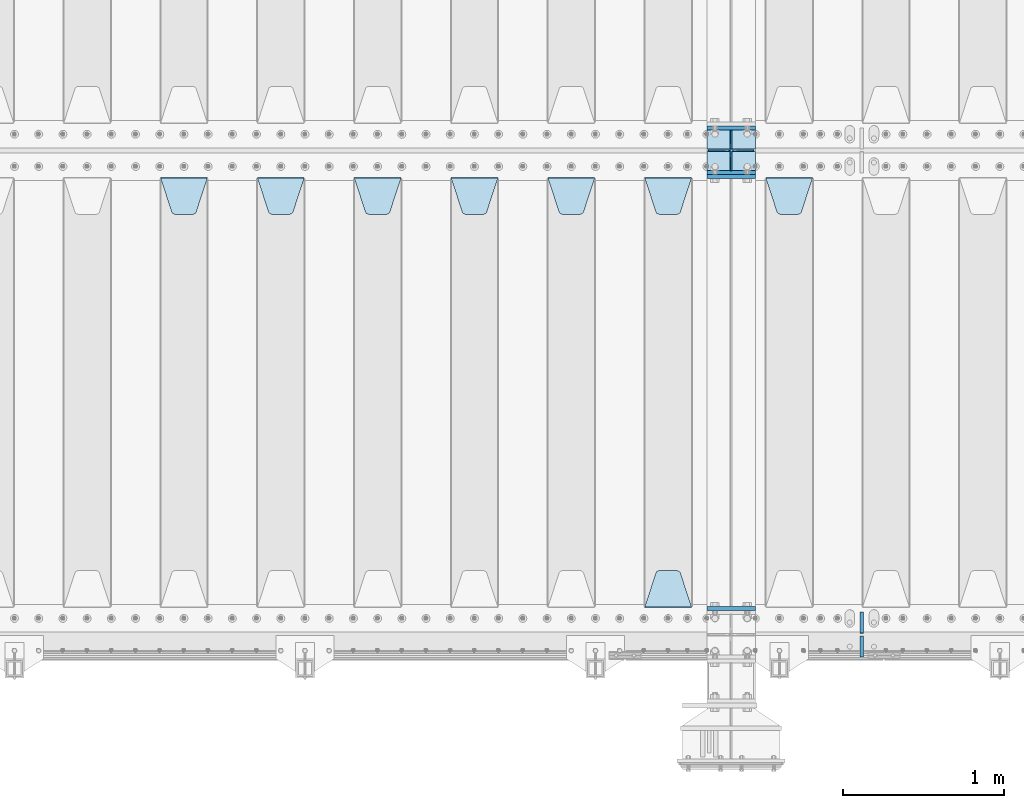
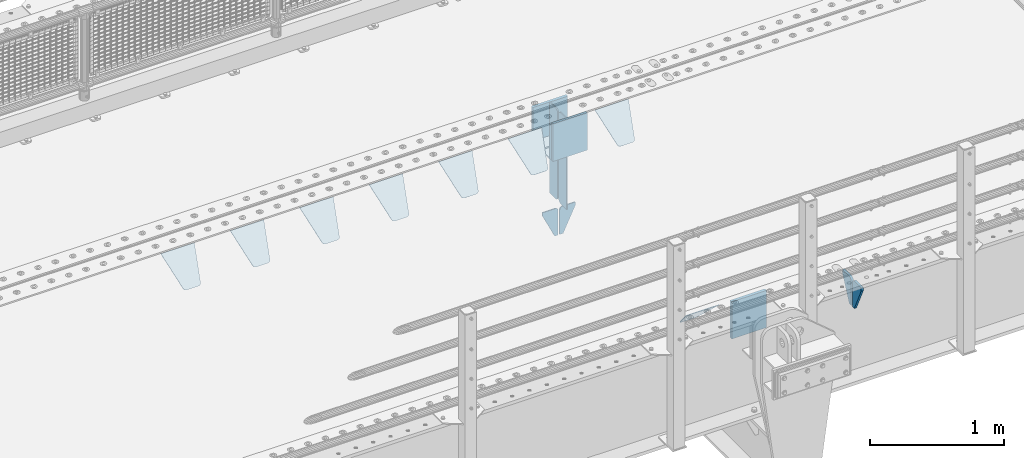
# One storey, part 167 of 193: 22 plates.
"""IFC2X3 building model written with IfcOpenShell, lengths in millimetres."""

from ifc_helpers import new_model, si_unit, frame, origin_with_axes, place, context, subcontext, project, spatial, faceted_brep, material, type_object, element, save


model = new_model("IFC2X3")

# Units and contexts
model_context = context("Model", 3, precision=1e-05, world=origin_with_axes())
body_context = subcontext(model_context, "Body", "Model", "MODEL_VIEW")
ifc_project = project(units=[si_unit("LENGTHUNIT", "METRE", prefix="MILLI"), si_unit("AREAUNIT", "SQUARE_METRE"), si_unit("VOLUMEUNIT", "CUBIC_METRE"), si_unit("MASSUNIT", "GRAM", prefix="KILO"), si_unit("TIMEUNIT", "SECOND"), si_unit("PLANEANGLEUNIT", "RADIAN"), si_unit("SOLIDANGLEUNIT", "STERADIAN"), si_unit("THERMODYNAMICTEMPERATUREUNIT", "DEGREE_CELSIUS"), si_unit("LUMINOUSINTENSITYUNIT", "LUMEN")], contexts=[model_context])

# Site, building, storey
site_placement = place(None, origin_with_axes())
site = spatial("IfcSite", under=ifc_project, at=site_placement, CompositionType="ELEMENT")
building_placement = place(site_placement, origin_with_axes())
building = spatial("IfcBuilding", under=site, at=building_placement, Name="Standard", CompositionType="ELEMENT")
storey_placement = place(building_placement, origin_with_axes())
storey = spatial("IfcBuildingStorey", under=building, at=storey_placement, Name="Undefined", CompositionType="ELEMENT", Elevation=0.0)

# Plates
ifc_material = material(Name="STEEL/S355N")
plate_type_1 = type_object("IfcPlateType", PredefinedType="NOTDEFINED")
for number, where, z_axis, x_axis in (
    (1, (-32210.0, 27137.5, -340.0), (0.0, 0.0, 1.0), (1.0, 0.0, 0.0)),
    (2, (-32210.0, 26862.5, -340.0), (0.0, 0.0, 1.0), (1.0, 0.0, 0.0)),
):
    element("IfcPlate", number, at=place(storey_placement, frame(where, z_axis=z_axis, x_axis=x_axis)), inside=storey, type_object=plate_type_1, material=ifc_material, context=body_context, shape_type="Brep", body=[
        faceted_brep([(0.0, -12.5, 0.0), (0.0, -12.5, 310.0), (0.0, 12.5, 310.0), (0.0, 12.5, 0.0), (300.0, -12.5, 310.0), (300.0, 12.5, 310.0), (300.0, -12.5, 0.0), (300.0, 12.5, 0.0)], [[[0, 1, 2, 3]], [[1, 4, 5, 2]], [[4, 6, 7, 5]], [[6, 0, 3, 7]], [[5, 7, 3, 2]], [[6, 4, 1, 0]]]),
    ])
for number, where, z_axis, x_axis in (
    (3, (-32210.0, 26837.5, -340.000000000044), (0.0, 0.0, 1.0), (1.0, 0.0, 0.0)),
    (4, (-32210.0, 24162.5, -340.000000000044), (0.0, 0.0, 1.0), (1.0, 0.0, 0.0)),
):
    element("IfcPlate", number, at=place(storey_placement, frame(where, z_axis=z_axis, x_axis=x_axis)), inside=storey, type_object=plate_type_1, material=ifc_material, context=body_context, shape_type="Brep", body=[
        faceted_brep([(0.0, -12.5, 0.0), (9.27684595808387e-10, -12.5, 340.0), (9.27684595808387e-10, 12.5, 340.0), (0.0, 12.5, 0.0), (300.0, -12.5, 340.0), (300.0, 12.5, 340.0), (300.0, -12.5, 0.0), (300.0, 12.5, 0.0)], [[[0, 1, 2, 3]], [[1, 4, 5, 2]], [[4, 6, 7, 5]], [[6, 0, 3, 7]], [[5, 7, 3, 2]], [[6, 4, 1, 0]]]),
    ])
plate_type_2 = type_object("IfcPlateType", PredefinedType="NOTDEFINED")
for number, where, z_axis, x_axis in (
    (5, (-32210.0, 26992.0, -343.0), (0.0, -1.0, 0.0), (1.0, 0.0, 0.0)),
    (6, (-32210.0, 27008.0, -343.0), (0.0, 1.0, 0.0), (1.0, 0.0, 0.0)),
):
    element("IfcPlate", number, at=place(storey_placement, frame(where, z_axis=z_axis, x_axis=x_axis)), inside=storey, type_object=plate_type_2, material=ifc_material, context=body_context, shape_type="Brep", body=[
        faceted_brep([(0.0, -7.0, 0.0), (0.0, -7.0, 117.0), (0.0, 7.0, 117.0), (0.0, 7.0, 0.0), (300.0, -7.0, 117.0), (300.0, 7.0, 117.0), (300.0, -7.0, 0.0), (300.0, 7.0, 0.0)], [[[0, 1, 2, 3]], [[1, 4, 5, 2]], [[4, 6, 7, 5]], [[6, 0, 3, 7]], [[5, 7, 3, 2]], [[6, 4, 1, 0]]]),
    ])
plate_type_3 = type_object("IfcPlateType", PredefinedType="NOTDEFINED")
for number, where, z_axis, x_axis in (
    (7, (-32060.0, 27008.0, -30.0), (0.0, 0.0, -1.0), (0.0, 1.0, 0.0)),
    (8, (-32060.0, 26992.0, -30.0), (0.0, 0.0, -1.0), (0.0, -1.0, 0.0)),
):
    element("IfcPlate", number, at=place(storey_placement, frame(where, z_axis=z_axis, x_axis=x_axis)), inside=storey, type_object=plate_type_3, material=ifc_material, context=body_context, shape_type="Brep", body=[
        faceted_brep([(0.0, -5.0, 30.0), (0.0, -5.0, 306.0), (0.0, 5.0, 306.0), (0.0, 5.0, 30.0), (117.0, -5.0, 306.0), (117.0, 5.0, 306.0), (117.0, -5.0, 0.0), (117.0, 5.0, 0.0), (30.0, -5.0, 0.0), (30.0, 5.0, 0.0), (24.7905546699913, -5.0, 0.455767409633758), (24.7905546699913, 5.0, 0.455767409633758), (19.7393957002314, -5.0, 1.80922137642275), (19.7393957002314, 5.0, 1.80922137642275), (15.0, -5.0, 4.01923788646684), (15.0, 5.0, 4.01923788646684), (10.7163717094045, -5.0, 7.01866670643066), (10.7163717094045, 5.0, 7.01866670643066), (7.01866670642994, -5.0, 10.7163717094038), (7.01866670642994, 5.0, 10.7163717094038), (4.01923788646673, -5.0, 15.0), (4.01923788646673, 5.0, 15.0), (1.80922137642119, -5.0, 19.7393957002299), (1.80922137642119, 5.0, 19.7393957002299), (0.455767409632244, -5.0, 24.7905546699921), (0.455767409632244, 5.0, 24.7905546699921)], [[[0, 1, 2, 3]], [[1, 4, 5, 2]], [[4, 6, 7, 5]], [[6, 8, 9, 7]], [[8, 10, 11, 9]], [[10, 12, 13, 11]], [[12, 14, 15, 13]], [[14, 16, 17, 15]], [[16, 18, 19, 17]], [[18, 20, 21, 19]], [[20, 22, 23, 21]], [[22, 24, 25, 23]], [[24, 0, 3, 25]], [[5, 7, 9, 11, 13, 15, 17, 19, 21, 23, 25, 3, 2]], [[24, 22, 20, 18, 16, 14, 12, 10, 8, 6, 4, 1, 0]]]),
    ])
for number, where, z_axis, x_axis in (
    (9, (-32060.0, 26992.0, -350.0), (0.0, 0.0, -1.0), (0.0, -1.0, 0.0)),
    (10, (-32060.0, 27008.0, -350.0), (0.0, 0.0, -1.0), (0.0, 1.0, 0.0)),
):
    element("IfcPlate", number, at=place(storey_placement, frame(where, z_axis=z_axis, x_axis=x_axis)), inside=storey, type_object=plate_type_3, material=ifc_material, context=body_context, shape_type="Brep", body=[
        faceted_brep([(0.0, -5.0, 0.0), (0.0, -5.0, 480.0), (0.0, 5.0, 480.0), (0.0, 5.0, 0.0), (0.455767409632244, -5.0, 485.209445330008), (0.455767409632244, 5.0, 485.209445330008), (1.80922137642119, -5.0, 490.26060429977), (1.80922137642119, 5.0, 490.26060429977), (4.01923788646673, -5.0, 495.0), (4.01923788646673, 5.0, 495.0), (7.01866670642994, -5.0, 499.283628290596), (7.01866670642994, 5.0, 499.283628290596), (10.7163717094045, -5.0, 502.981333293569), (10.7163717094045, 5.0, 502.981333293569), (15.0, -5.0, 505.980762113533), (15.0, 5.0, 505.980762113533), (19.7393957002314, -5.0, 508.190778623577), (19.7393957002314, 5.0, 508.190778623577), (24.7905546699913, -5.0, 509.544232590366), (24.7905546699913, 5.0, 509.544232590366), (30.0, -5.0, 510.0), (30.0, 5.0, 510.0), (117.0, -5.0, 510.0), (117.0, 5.0, 510.0), (117.0, -5.0, 0.0), (117.0, 5.0, 0.0)], [[[0, 1, 2, 3]], [[1, 4, 5, 2]], [[4, 6, 7, 5]], [[6, 8, 9, 7]], [[8, 10, 11, 9]], [[10, 12, 13, 11]], [[12, 14, 15, 13]], [[14, 16, 17, 15]], [[16, 18, 19, 17]], [[18, 20, 21, 19]], [[20, 22, 23, 21]], [[22, 24, 25, 23]], [[24, 0, 3, 25]], [[5, 7, 9, 11, 13, 15, 17, 19, 21, 23, 25, 3, 2]], [[24, 22, 20, 18, 16, 14, 12, 10, 8, 6, 4, 1, 0]]]),
    ])
plate_type_4 = type_object("IfcPlateType", PredefinedType="NOTDEFINED")
for number, where, z_axis, x_axis in (
    (11, (-32066.4999999343, 26999.9999999954, -915.000018206184), (0.0, 0.0, -1.0), (-1.0, 0.0, 0.0)),
    (12, (-32053.4999999343, 26999.9999999954, -915.000018206184), (0.0, 0.0, -1.0), (1.0, 0.0, 0.0)),
):
    element("IfcPlate", number, at=place(storey_placement, frame(where, z_axis=z_axis, x_axis=x_axis)), inside=storey, type_object=plate_type_4, material=ifc_material, context=body_context, shape_type="Brep", body=[
        faceted_brep([(0.0, -5.0, 27.0), (0.0, -5.0, 250.0), (0.0, 5.0, 250.0), (0.0, 5.0, 27.0), (30.0, -5.0, 250.0), (30.0, 5.0, 250.0), (135.0, -5.0, 30.0), (135.0, 5.0, 30.0), (135.0, -5.0, 0.0), (135.0, 5.0, 0.0), (27.0, -5.0, 0.0), (27.0, 5.0, 0.0), (22.3114992029914, -5.0, 0.410190668670339), (22.3114992029914, 5.0, 0.410190668670339), (17.7654561302079, -5.0, 1.62829923878041), (17.7654561302079, 5.0, 1.62829923878041), (13.5, -5.0, 3.61731409782021), (13.5, 5.0, 3.61731409782021), (9.64473453846222, -5.0, 6.31680003578765), (9.64473453846222, 5.0, 6.31680003578765), (6.31680003578731, -5.0, 9.64473453846347), (6.31680003578731, 5.0, 9.64473453846347), (3.61731409782078, -5.0, 13.5), (3.61731409782078, 5.0, 13.5), (1.62829923877871, -5.0, 17.765456130207), (1.62829923877871, 5.0, 17.765456130207), (0.410190668670111, -5.0, 22.3114992029929), (0.410190668670111, 5.0, 22.3114992029929)], [[[0, 1, 2, 3]], [[1, 4, 5, 2]], [[4, 6, 7, 5]], [[6, 8, 9, 7]], [[8, 10, 11, 9]], [[10, 12, 13, 11]], [[12, 14, 15, 13]], [[14, 16, 17, 15]], [[16, 18, 19, 17]], [[18, 20, 21, 19]], [[20, 22, 23, 21]], [[22, 24, 25, 23]], [[24, 26, 27, 25]], [[26, 0, 3, 27]], [[5, 7, 9, 11, 13, 15, 17, 19, 21, 23, 25, 27, 3, 2]], [[26, 24, 22, 20, 18, 16, 14, 12, 10, 8, 6, 4, 1, 0]]]),
    ])
plate_type_5 = type_object("IfcPlateType", PredefinedType="NOTDEFINED")
plate_1_placement = place(storey_placement, frame((-31845.0, 26831.767766956, -1.76776695296758), z_axis=(0.0, -0.707106781186547, -0.707106781186548), x_axis=(1.0, 0.0, 0.0)))
element("IfcPlate", 13, at=plate_1_placement, inside=storey, type_object=plate_type_5, material=ifc_material, context=body_context, shape_type="Brep", body=[
    faceted_brep([(0.0, -2.5, 0.0), (69.345504679477, -2.50000000000364, 300.171731424831), (69.345504679477, 2.49999999999636, 300.171731424831), (0.0, 2.5, 0.0), (70.9274061199576, -2.50000000000364, 304.897442415397), (70.9274061199576, 2.49999999999636, 304.897442415397), (73.3818627772307, -2.50000000000364, 309.234538108529), (73.3818627772307, 2.49999999999636, 309.234538108529), (76.6187032999551, -2.50000000000728, 313.023683126103), (76.6187032999551, 2.49999999999636, 313.023683126103), (80.5190132704993, -2.50000000000364, 316.125672595372), (80.5190132704993, 2.49999999999636, 316.125672595368), (84.9395038596849, -2.50000000000364, 318.426546230472), (84.9395038596849, 2.49999999999636, 318.426546230476), (89.7177759439219, -2.50000000000364, 319.841774983273), (89.7177759439219, 2.49999999999636, 319.841774983277), (94.678286292652, -2.50000000000364, 320.319366455074), (94.678286292652, 2.49999999999636, 320.319366455074), (195.321713707348, -2.50000000000364, 320.319366455074), (195.321713707348, 2.49999999999636, 320.319366455074), (200.282224056078, -2.50000000000364, 319.841774983273), (200.282224056078, 2.49999999999636, 319.841774983277), (205.060496140315, -2.50000000000364, 318.426546230472), (205.060496140315, 2.49999999999636, 318.426546230472), (209.480986729501, -2.50000000000364, 316.125672595372), (209.480986729501, 2.49999999999636, 316.125672595368), (213.381296700045, -2.50000000000728, 313.023683126103), (213.381296700045, 2.49999999999272, 313.023683126103), (216.618137222769, -2.50000000000364, 309.234538108525), (216.618137222769, 2.49999999999636, 309.234538108522), (219.072593880042, -2.50000000000364, 304.897442415397), (219.072593880042, 2.49999999999636, 304.897442415397), (220.654495320523, -2.50000000000364, 300.171731424831), (220.654495320523, 2.49999999999636, 300.171731424831), (290.0, -2.50000000000364, 0.0), (290.0, 2.49999999999636, 0.0)], [[[0, 1, 2, 3]], [[1, 4, 5, 2]], [[4, 6, 7, 5]], [[6, 8, 9, 7]], [[8, 10, 11, 9]], [[10, 12, 13, 11]], [[12, 14, 15, 13]], [[14, 16, 17, 15]], [[16, 18, 19, 17]], [[18, 20, 21, 19]], [[20, 22, 23, 21]], [[22, 24, 25, 23]], [[24, 26, 27, 25]], [[26, 28, 29, 27]], [[28, 30, 31, 29]], [[30, 32, 33, 31]], [[32, 34, 35, 33]], [[34, 0, 3, 35]], [[5, 7, 9, 11, 13, 15, 17, 19, 21, 23, 25, 27, 29, 31, 33, 35, 3, 2]], [[34, 32, 30, 28, 26, 24, 22, 20, 18, 16, 14, 12, 10, 8, 6, 4, 1, 0]]]),
])
plate_2_placement = place(storey_placement, frame((-32595.0, 26831.767766956, -1.76776695296758), z_axis=(0.0, -0.707106781186547, -0.707106781186548), x_axis=(1.0, 0.0, 0.0)))
element("IfcPlate", 14, at=plate_2_placement, inside=storey, type_object=plate_type_5, material=ifc_material, context=body_context, shape_type="Brep", body=[
    faceted_brep([(0.0, -2.5, 0.0), (69.345504679477, -2.50000000000364, 300.171731424831), (69.345504679477, 2.49999999999636, 300.171731424831), (0.0, 2.5, 0.0), (70.9274061199576, -2.50000000000364, 304.897442415397), (70.9274061199576, 2.49999999999636, 304.897442415397), (73.3818627772307, -2.50000000000364, 309.234538108529), (73.3818627772307, 2.49999999999636, 309.234538108529), (76.6187032999551, -2.50000000000728, 313.023683126103), (76.6187032999551, 2.49999999999636, 313.023683126103), (80.5190132704993, -2.50000000000364, 316.125672595372), (80.5190132704993, 2.49999999999636, 316.125672595368), (84.9395038596849, -2.50000000000364, 318.426546230472), (84.9395038596849, 2.49999999999636, 318.426546230476), (89.7177759439219, -2.50000000000364, 319.841774983273), (89.7177759439219, 2.49999999999636, 319.841774983277), (94.678286292652, -2.50000000000364, 320.319366455074), (94.678286292652, 2.49999999999636, 320.319366455074), (195.321713707348, -2.50000000000364, 320.319366455074), (195.321713707348, 2.49999999999636, 320.319366455074), (200.282224056078, -2.50000000000364, 319.841774983273), (200.282224056078, 2.49999999999636, 319.841774983277), (205.060496140315, -2.50000000000364, 318.426546230472), (205.060496140315, 2.49999999999636, 318.426546230472), (209.480986729501, -2.50000000000364, 316.125672595372), (209.480986729501, 2.49999999999636, 316.125672595368), (213.381296700045, -2.50000000000728, 313.023683126103), (213.381296700045, 2.49999999999272, 313.023683126103), (216.618137222769, -2.50000000000364, 309.234538108525), (216.618137222769, 2.49999999999636, 309.234538108522), (219.072593880042, -2.50000000000364, 304.897442415397), (219.072593880042, 2.49999999999636, 304.897442415397), (220.654495320523, -2.50000000000364, 300.171731424831), (220.654495320523, 2.49999999999636, 300.171731424831), (290.0, -2.50000000000364, 0.0), (290.0, 2.49999999999636, 0.0)], [[[0, 1, 2, 3]], [[1, 4, 5, 2]], [[4, 6, 7, 5]], [[6, 8, 9, 7]], [[8, 10, 11, 9]], [[10, 12, 13, 11]], [[12, 14, 15, 13]], [[14, 16, 17, 15]], [[16, 18, 19, 17]], [[18, 20, 21, 19]], [[20, 22, 23, 21]], [[22, 24, 25, 23]], [[24, 26, 27, 25]], [[26, 28, 29, 27]], [[28, 30, 31, 29]], [[30, 32, 33, 31]], [[32, 34, 35, 33]], [[34, 0, 3, 35]], [[5, 7, 9, 11, 13, 15, 17, 19, 21, 23, 25, 27, 29, 31, 33, 35, 3, 2]], [[34, 32, 30, 28, 26, 24, 22, 20, 18, 16, 14, 12, 10, 8, 6, 4, 1, 0]]]),
])
plate_3_placement = place(storey_placement, frame((-32305.0, 24168.232233047, -1.76776695296758), z_axis=(0.0, 0.707106781186547, -0.707106781186548), x_axis=(-1.0, 0.0, 0.0)))
element("IfcPlate", 15, at=plate_3_placement, inside=storey, type_object=plate_type_5, material=ifc_material, context=body_context, shape_type="Brep", body=[
    faceted_brep([(0.0, -2.5, 0.0), (69.345504679477, -2.50000000000364, 300.171731424831), (69.345504679477, 2.49999999999636, 300.171731424831), (0.0, 2.5, 0.0), (70.9274061199576, -2.50000000000364, 304.897442415397), (70.9274061199576, 2.49999999999636, 304.897442415397), (73.3818627772307, -2.50000000000364, 309.234538108529), (73.3818627772307, 2.49999999999636, 309.234538108529), (76.6187032999551, -2.50000000000728, 313.023683126103), (76.6187032999551, 2.49999999999636, 313.023683126103), (80.5190132704993, -2.50000000000364, 316.125672595372), (80.5190132704993, 2.49999999999636, 316.125672595368), (84.9395038596849, -2.50000000000364, 318.426546230472), (84.9395038596849, 2.49999999999636, 318.426546230476), (89.7177759439219, -2.50000000000364, 319.841774983273), (89.7177759439219, 2.49999999999636, 319.841774983277), (94.678286292652, -2.50000000000364, 320.319366455074), (94.678286292652, 2.49999999999636, 320.319366455074), (195.321713707348, -2.50000000000364, 320.319366455074), (195.321713707348, 2.49999999999636, 320.319366455074), (200.282224056078, -2.50000000000364, 319.841774983273), (200.282224056078, 2.49999999999636, 319.841774983277), (205.060496140315, -2.50000000000364, 318.426546230472), (205.060496140315, 2.49999999999636, 318.426546230472), (209.480986729501, -2.50000000000364, 316.125672595372), (209.480986729501, 2.49999999999636, 316.125672595368), (213.381296700045, -2.50000000000728, 313.023683126103), (213.381296700045, 2.49999999999272, 313.023683126103), (216.618137222769, -2.50000000000364, 309.234538108525), (216.618137222769, 2.49999999999636, 309.234538108522), (219.072593880042, -2.50000000000364, 304.897442415397), (219.072593880042, 2.49999999999636, 304.897442415397), (220.654495320523, -2.50000000000364, 300.171731424831), (220.654495320523, 2.49999999999636, 300.171731424831), (290.0, -2.50000000000364, 0.0), (290.0, 2.49999999999636, 0.0)], [[[0, 1, 2, 3]], [[1, 4, 5, 2]], [[4, 6, 7, 5]], [[6, 8, 9, 7]], [[8, 10, 11, 9]], [[10, 12, 13, 11]], [[12, 14, 15, 13]], [[14, 16, 17, 15]], [[16, 18, 19, 17]], [[18, 20, 21, 19]], [[20, 22, 23, 21]], [[22, 24, 25, 23]], [[24, 26, 27, 25]], [[26, 28, 29, 27]], [[28, 30, 31, 29]], [[30, 32, 33, 31]], [[32, 34, 35, 33]], [[34, 0, 3, 35]], [[5, 7, 9, 11, 13, 15, 17, 19, 21, 23, 25, 27, 29, 31, 33, 35, 3, 2]], [[34, 32, 30, 28, 26, 24, 22, 20, 18, 16, 14, 12, 10, 8, 6, 4, 1, 0]]]),
])
plate_4_placement = place(storey_placement, frame((-33195.0, 26831.767766956, -1.76776695296758), z_axis=(0.0, -0.707106781186547, -0.707106781186548), x_axis=(1.0, 0.0, 0.0)))
element("IfcPlate", 16, at=plate_4_placement, inside=storey, type_object=plate_type_5, material=ifc_material, context=body_context, shape_type="Brep", body=[
    faceted_brep([(0.0, -2.5, 0.0), (69.345504679477, -2.50000000000364, 300.171731424831), (69.345504679477, 2.49999999999636, 300.171731424831), (0.0, 2.5, 0.0), (70.9274061199576, -2.50000000000364, 304.897442415397), (70.9274061199576, 2.49999999999636, 304.897442415397), (73.3818627772307, -2.50000000000364, 309.234538108529), (73.3818627772307, 2.49999999999636, 309.234538108529), (76.6187032999551, -2.50000000000728, 313.023683126103), (76.6187032999551, 2.49999999999636, 313.023683126103), (80.5190132704993, -2.50000000000364, 316.125672595372), (80.5190132704993, 2.49999999999636, 316.125672595368), (84.9395038596849, -2.50000000000364, 318.426546230472), (84.9395038596849, 2.49999999999636, 318.426546230476), (89.7177759439219, -2.50000000000364, 319.841774983273), (89.7177759439219, 2.49999999999636, 319.841774983277), (94.678286292652, -2.50000000000364, 320.319366455074), (94.678286292652, 2.49999999999636, 320.319366455074), (195.321713707348, -2.50000000000364, 320.319366455074), (195.321713707348, 2.49999999999636, 320.319366455074), (200.282224056078, -2.50000000000364, 319.841774983273), (200.282224056078, 2.49999999999636, 319.841774983277), (205.060496140315, -2.50000000000364, 318.426546230472), (205.060496140315, 2.49999999999636, 318.426546230472), (209.480986729501, -2.50000000000364, 316.125672595372), (209.480986729501, 2.49999999999636, 316.125672595368), (213.381296700045, -2.50000000000728, 313.023683126103), (213.381296700045, 2.49999999999272, 313.023683126103), (216.618137222769, -2.50000000000364, 309.234538108525), (216.618137222769, 2.49999999999636, 309.234538108522), (219.072593880042, -2.50000000000364, 304.897442415397), (219.072593880042, 2.49999999999636, 304.897442415397), (220.654495320523, -2.50000000000364, 300.171731424831), (220.654495320523, 2.49999999999636, 300.171731424831), (290.0, -2.50000000000364, 0.0), (290.0, 2.49999999999636, 0.0)], [[[0, 1, 2, 3]], [[1, 4, 5, 2]], [[4, 6, 7, 5]], [[6, 8, 9, 7]], [[8, 10, 11, 9]], [[10, 12, 13, 11]], [[12, 14, 15, 13]], [[14, 16, 17, 15]], [[16, 18, 19, 17]], [[18, 20, 21, 19]], [[20, 22, 23, 21]], [[22, 24, 25, 23]], [[24, 26, 27, 25]], [[26, 28, 29, 27]], [[28, 30, 31, 29]], [[30, 32, 33, 31]], [[32, 34, 35, 33]], [[34, 0, 3, 35]], [[5, 7, 9, 11, 13, 15, 17, 19, 21, 23, 25, 27, 29, 31, 33, 35, 3, 2]], [[34, 32, 30, 28, 26, 24, 22, 20, 18, 16, 14, 12, 10, 8, 6, 4, 1, 0]]]),
])
plate_5_placement = place(storey_placement, frame((-33795.0, 26831.767766956, -1.76776695296758), z_axis=(0.0, -0.707106781186547, -0.707106781186548), x_axis=(1.0, 0.0, 0.0)))
element("IfcPlate", 17, at=plate_5_placement, inside=storey, type_object=plate_type_5, material=ifc_material, context=body_context, shape_type="Brep", body=[
    faceted_brep([(0.0, -2.5, 0.0), (69.345504679477, -2.50000000000364, 300.171731424831), (69.345504679477, 2.49999999999636, 300.171731424831), (0.0, 2.5, 0.0), (70.9274061199576, -2.50000000000364, 304.897442415397), (70.9274061199576, 2.49999999999636, 304.897442415397), (73.3818627772307, -2.50000000000364, 309.234538108529), (73.3818627772307, 2.49999999999636, 309.234538108529), (76.6187032999551, -2.50000000000728, 313.023683126103), (76.6187032999551, 2.49999999999636, 313.023683126103), (80.5190132704993, -2.50000000000364, 316.125672595372), (80.5190132704993, 2.49999999999636, 316.125672595368), (84.9395038596849, -2.50000000000364, 318.426546230472), (84.9395038596849, 2.49999999999636, 318.426546230476), (89.7177759439219, -2.50000000000364, 319.841774983273), (89.7177759439219, 2.49999999999636, 319.841774983277), (94.678286292652, -2.50000000000364, 320.319366455074), (94.678286292652, 2.49999999999636, 320.319366455074), (195.321713707348, -2.50000000000364, 320.319366455074), (195.321713707348, 2.49999999999636, 320.319366455074), (200.282224056078, -2.50000000000364, 319.841774983273), (200.282224056078, 2.49999999999636, 319.841774983277), (205.060496140315, -2.50000000000364, 318.426546230472), (205.060496140315, 2.49999999999636, 318.426546230472), (209.480986729501, -2.50000000000364, 316.125672595372), (209.480986729501, 2.49999999999636, 316.125672595368), (213.381296700045, -2.50000000000728, 313.023683126103), (213.381296700045, 2.49999999999272, 313.023683126103), (216.618137222769, -2.50000000000364, 309.234538108525), (216.618137222769, 2.49999999999636, 309.234538108522), (219.072593880042, -2.50000000000364, 304.897442415397), (219.072593880042, 2.49999999999636, 304.897442415397), (220.654495320523, -2.50000000000364, 300.171731424831), (220.654495320523, 2.49999999999636, 300.171731424831), (290.0, -2.50000000000364, 0.0), (290.0, 2.49999999999636, 0.0)], [[[0, 1, 2, 3]], [[1, 4, 5, 2]], [[4, 6, 7, 5]], [[6, 8, 9, 7]], [[8, 10, 11, 9]], [[10, 12, 13, 11]], [[12, 14, 15, 13]], [[14, 16, 17, 15]], [[16, 18, 19, 17]], [[18, 20, 21, 19]], [[20, 22, 23, 21]], [[22, 24, 25, 23]], [[24, 26, 27, 25]], [[26, 28, 29, 27]], [[28, 30, 31, 29]], [[30, 32, 33, 31]], [[32, 34, 35, 33]], [[34, 0, 3, 35]], [[5, 7, 9, 11, 13, 15, 17, 19, 21, 23, 25, 27, 29, 31, 33, 35, 3, 2]], [[34, 32, 30, 28, 26, 24, 22, 20, 18, 16, 14, 12, 10, 8, 6, 4, 1, 0]]]),
])
plate_6_placement = place(storey_placement, frame((-34395.0, 26831.767766956, -1.76776695296758), z_axis=(0.0, -0.707106781186547, -0.707106781186548), x_axis=(1.0, 0.0, 0.0)))
element("IfcPlate", 18, at=plate_6_placement, inside=storey, type_object=plate_type_5, material=ifc_material, context=body_context, shape_type="Brep", body=[
    faceted_brep([(0.0, -2.5, 0.0), (69.345504679477, -2.50000000000364, 300.171731424831), (69.345504679477, 2.49999999999636, 300.171731424831), (0.0, 2.5, 0.0), (70.9274061199576, -2.50000000000364, 304.897442415397), (70.9274061199576, 2.49999999999636, 304.897442415397), (73.3818627772307, -2.50000000000364, 309.234538108529), (73.3818627772307, 2.49999999999636, 309.234538108529), (76.6187032999551, -2.50000000000728, 313.023683126103), (76.6187032999551, 2.49999999999636, 313.023683126103), (80.5190132704993, -2.50000000000364, 316.125672595372), (80.5190132704993, 2.49999999999636, 316.125672595368), (84.9395038596849, -2.50000000000364, 318.426546230472), (84.9395038596849, 2.49999999999636, 318.426546230476), (89.7177759439219, -2.50000000000364, 319.841774983273), (89.7177759439219, 2.49999999999636, 319.841774983277), (94.678286292652, -2.50000000000364, 320.319366455074), (94.678286292652, 2.49999999999636, 320.319366455074), (195.321713707348, -2.50000000000364, 320.319366455074), (195.321713707348, 2.49999999999636, 320.319366455074), (200.282224056078, -2.50000000000364, 319.841774983273), (200.282224056078, 2.49999999999636, 319.841774983277), (205.060496140315, -2.50000000000364, 318.426546230472), (205.060496140315, 2.49999999999636, 318.426546230472), (209.480986729501, -2.50000000000364, 316.125672595372), (209.480986729501, 2.49999999999636, 316.125672595368), (213.381296700045, -2.50000000000728, 313.023683126103), (213.381296700045, 2.49999999999272, 313.023683126103), (216.618137222769, -2.50000000000364, 309.234538108525), (216.618137222769, 2.49999999999636, 309.234538108522), (219.072593880042, -2.50000000000364, 304.897442415397), (219.072593880042, 2.49999999999636, 304.897442415397), (220.654495320523, -2.50000000000364, 300.171731424831), (220.654495320523, 2.49999999999636, 300.171731424831), (290.0, -2.50000000000364, 0.0), (290.0, 2.49999999999636, 0.0)], [[[0, 1, 2, 3]], [[1, 4, 5, 2]], [[4, 6, 7, 5]], [[6, 8, 9, 7]], [[8, 10, 11, 9]], [[10, 12, 13, 11]], [[12, 14, 15, 13]], [[14, 16, 17, 15]], [[16, 18, 19, 17]], [[18, 20, 21, 19]], [[20, 22, 23, 21]], [[22, 24, 25, 23]], [[24, 26, 27, 25]], [[26, 28, 29, 27]], [[28, 30, 31, 29]], [[30, 32, 33, 31]], [[32, 34, 35, 33]], [[34, 0, 3, 35]], [[5, 7, 9, 11, 13, 15, 17, 19, 21, 23, 25, 27, 29, 31, 33, 35, 3, 2]], [[34, 32, 30, 28, 26, 24, 22, 20, 18, 16, 14, 12, 10, 8, 6, 4, 1, 0]]]),
])
plate_7_placement = place(storey_placement, frame((-34995.0, 26831.767766956, -1.76776695296758), z_axis=(0.0, -0.707106781186547, -0.707106781186548), x_axis=(1.0, 0.0, 0.0)))
element("IfcPlate", 19, at=plate_7_placement, inside=storey, type_object=plate_type_5, material=ifc_material, context=body_context, shape_type="Brep", body=[
    faceted_brep([(0.0, -2.5, 0.0), (69.345504679477, -2.50000000000364, 300.171731424831), (69.345504679477, 2.49999999999636, 300.171731424831), (0.0, 2.5, 0.0), (70.9274061199576, -2.50000000000364, 304.897442415397), (70.9274061199576, 2.49999999999636, 304.897442415397), (73.3818627772307, -2.50000000000364, 309.234538108529), (73.3818627772307, 2.49999999999636, 309.234538108529), (76.6187032999551, -2.50000000000728, 313.023683126103), (76.6187032999551, 2.49999999999636, 313.023683126103), (80.5190132704993, -2.50000000000364, 316.125672595372), (80.5190132704993, 2.49999999999636, 316.125672595368), (84.9395038596849, -2.50000000000364, 318.426546230472), (84.9395038596849, 2.49999999999636, 318.426546230476), (89.7177759439219, -2.50000000000364, 319.841774983273), (89.7177759439219, 2.49999999999636, 319.841774983277), (94.678286292652, -2.50000000000364, 320.319366455074), (94.678286292652, 2.49999999999636, 320.319366455074), (195.321713707348, -2.50000000000364, 320.319366455074), (195.321713707348, 2.49999999999636, 320.319366455074), (200.282224056078, -2.50000000000364, 319.841774983273), (200.282224056078, 2.49999999999636, 319.841774983277), (205.060496140315, -2.50000000000364, 318.426546230472), (205.060496140315, 2.49999999999636, 318.426546230472), (209.480986729501, -2.50000000000364, 316.125672595372), (209.480986729501, 2.49999999999636, 316.125672595368), (213.381296700045, -2.50000000000728, 313.023683126103), (213.381296700045, 2.49999999999272, 313.023683126103), (216.618137222769, -2.50000000000364, 309.234538108525), (216.618137222769, 2.49999999999636, 309.234538108522), (219.072593880042, -2.50000000000364, 304.897442415397), (219.072593880042, 2.49999999999636, 304.897442415397), (220.654495320523, -2.50000000000364, 300.171731424831), (220.654495320523, 2.49999999999636, 300.171731424831), (290.0, -2.50000000000364, 0.0), (290.0, 2.49999999999636, 0.0)], [[[0, 1, 2, 3]], [[1, 4, 5, 2]], [[4, 6, 7, 5]], [[6, 8, 9, 7]], [[8, 10, 11, 9]], [[10, 12, 13, 11]], [[12, 14, 15, 13]], [[14, 16, 17, 15]], [[16, 18, 19, 17]], [[18, 20, 21, 19]], [[20, 22, 23, 21]], [[22, 24, 25, 23]], [[24, 26, 27, 25]], [[26, 28, 29, 27]], [[28, 30, 31, 29]], [[30, 32, 33, 31]], [[32, 34, 35, 33]], [[34, 0, 3, 35]], [[5, 7, 9, 11, 13, 15, 17, 19, 21, 23, 25, 27, 29, 31, 33, 35, 3, 2]], [[34, 32, 30, 28, 26, 24, 22, 20, 18, 16, 14, 12, 10, 8, 6, 4, 1, 0]]]),
])
plate_8_placement = place(storey_placement, frame((-35595.0, 26831.767766956, -1.76776695296758), z_axis=(0.0, -0.707106781186547, -0.707106781186548), x_axis=(1.0, 0.0, 0.0)))
element("IfcPlate", 20, at=plate_8_placement, inside=storey, type_object=plate_type_5, material=ifc_material, context=body_context, shape_type="Brep", body=[
    faceted_brep([(0.0, -2.5, 0.0), (69.345504679477, -2.50000000000364, 300.171731424831), (69.345504679477, 2.49999999999636, 300.171731424831), (0.0, 2.5, 0.0), (70.9274061199576, -2.50000000000364, 304.897442415397), (70.9274061199576, 2.49999999999636, 304.897442415397), (73.3818627772307, -2.50000000000364, 309.234538108529), (73.3818627772307, 2.49999999999636, 309.234538108529), (76.6187032999551, -2.50000000000728, 313.023683126103), (76.6187032999551, 2.49999999999636, 313.023683126103), (80.5190132704993, -2.50000000000364, 316.125672595372), (80.5190132704993, 2.49999999999636, 316.125672595368), (84.9395038596849, -2.50000000000364, 318.426546230472), (84.9395038596849, 2.49999999999636, 318.426546230476), (89.7177759439219, -2.50000000000364, 319.841774983273), (89.7177759439219, 2.49999999999636, 319.841774983277), (94.678286292652, -2.50000000000364, 320.319366455074), (94.678286292652, 2.49999999999636, 320.319366455074), (195.321713707348, -2.50000000000364, 320.319366455074), (195.321713707348, 2.49999999999636, 320.319366455074), (200.282224056078, -2.50000000000364, 319.841774983273), (200.282224056078, 2.49999999999636, 319.841774983277), (205.060496140315, -2.50000000000364, 318.426546230472), (205.060496140315, 2.49999999999636, 318.426546230472), (209.480986729501, -2.50000000000364, 316.125672595372), (209.480986729501, 2.49999999999636, 316.125672595368), (213.381296700045, -2.50000000000728, 313.023683126103), (213.381296700045, 2.49999999999272, 313.023683126103), (216.618137222769, -2.50000000000364, 309.234538108525), (216.618137222769, 2.49999999999636, 309.234538108522), (219.072593880042, -2.50000000000364, 304.897442415397), (219.072593880042, 2.49999999999636, 304.897442415397), (220.654495320523, -2.50000000000364, 300.171731424831), (220.654495320523, 2.49999999999636, 300.171731424831), (290.0, -2.50000000000364, 0.0), (290.0, 2.49999999999636, 0.0)], [[[0, 1, 2, 3]], [[1, 4, 5, 2]], [[4, 6, 7, 5]], [[6, 8, 9, 7]], [[8, 10, 11, 9]], [[10, 12, 13, 11]], [[12, 14, 15, 13]], [[14, 16, 17, 15]], [[16, 18, 19, 17]], [[18, 20, 21, 19]], [[20, 22, 23, 21]], [[22, 24, 25, 23]], [[24, 26, 27, 25]], [[26, 28, 29, 27]], [[28, 30, 31, 29]], [[30, 32, 33, 31]], [[32, 34, 35, 33]], [[34, 0, 3, 35]], [[5, 7, 9, 11, 13, 15, 17, 19, 21, 23, 25, 27, 29, 31, 33, 35, 3, 2]], [[34, 32, 30, 28, 26, 24, 22, 20, 18, 16, 14, 12, 10, 8, 6, 4, 1, 0]]]),
])
plate_type_6 = type_object("IfcPlateType", PredefinedType="NOTDEFINED")
for number, where, z_axis, x_axis in (
    (21, (-31250.0, 23860.0, -30.0), (0.0, 0.0, -1.0), (0.0, 1.0, 0.0)),
    (22, (-31250.0, 24140.0, -30.0), (0.0, 0.0, -1.0), (0.0, -1.0, 0.0)),
):
    element("IfcPlate", number, at=place(storey_placement, frame(where, z_axis=z_axis, x_axis=x_axis)), inside=storey, type_object=plate_type_6, material=ifc_material, context=body_context, shape_type="Brep", body=[
        faceted_brep([(0.0, -10.0, 0.0), (0.0, -10.0, 30.0), (0.0, 10.0, 30.0), (0.0, 10.0, 0.0), (102.0, -10.0, 250.0), (102.0, 10.0, 250.0), (132.0, -10.0, 250.0), (132.0, 10.0, 250.0), (132.0, -10.0, 30.0), (132.0, 10.0, 30.0), (131.544232590368, -10.0, 24.790554669992), (131.544232590368, 10.0, 24.790554669992), (130.190778623579, -10.0, 19.7393957002299), (130.190778623579, 10.0, 19.7393957002299), (127.980762113533, -10.0, 15.0), (127.980762113533, 10.0, 15.0), (124.98133329357, -10.0, 10.7163717094038), (124.98133329357, 10.0, 10.7163717094038), (121.283628290596, -10.0, 7.01866670643062), (121.283628290596, 10.0, 7.01866670643062), (117.0, -10.0, 4.01923788646684), (117.0, 10.0, 4.01923788646684), (112.260604299769, -10.0, 1.80922137642278), (112.260604299769, 10.0, 1.80922137642278), (107.209445330009, -10.0, 0.455767409633722), (107.209445330009, 10.0, 0.455767409633722), (102.0, -10.0, 0.0), (102.0, 10.0, 0.0)], [[[0, 1, 2, 3]], [[1, 4, 5, 2]], [[4, 6, 7, 5]], [[6, 8, 9, 7]], [[8, 10, 11, 9]], [[10, 12, 13, 11]], [[12, 14, 15, 13]], [[14, 16, 17, 15]], [[16, 18, 19, 17]], [[18, 20, 21, 19]], [[20, 22, 23, 21]], [[22, 24, 25, 23]], [[24, 26, 27, 25]], [[26, 0, 3, 27]], [[5, 7, 9, 11, 13, 15, 17, 19, 21, 23, 25, 27, 3, 2]], [[26, 24, 22, 20, 18, 16, 14, 12, 10, 8, 6, 4, 1, 0]]]),
    ])

save(model, "model.ifc")
